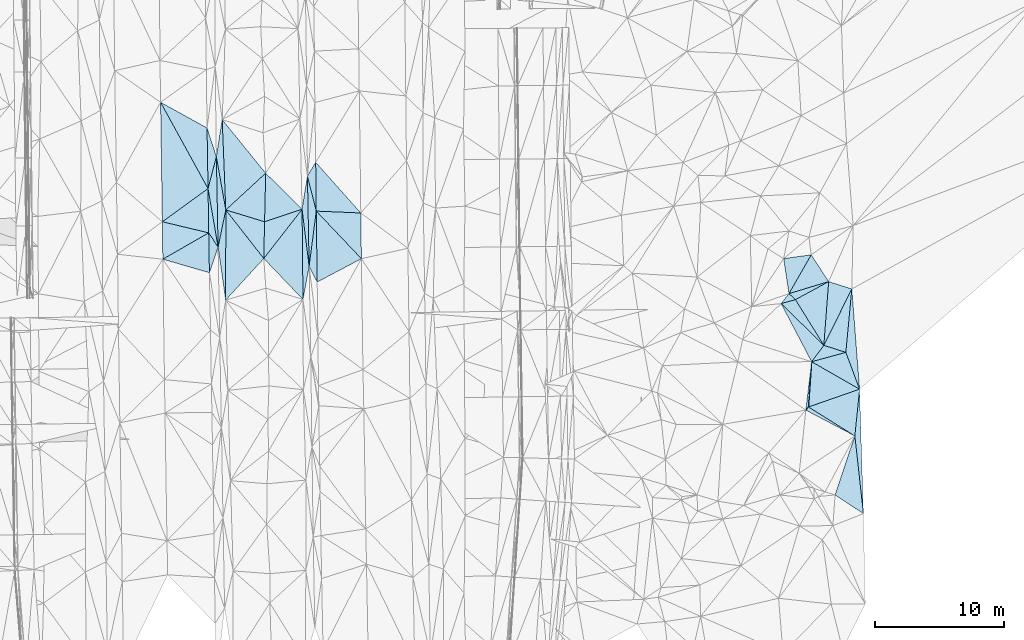
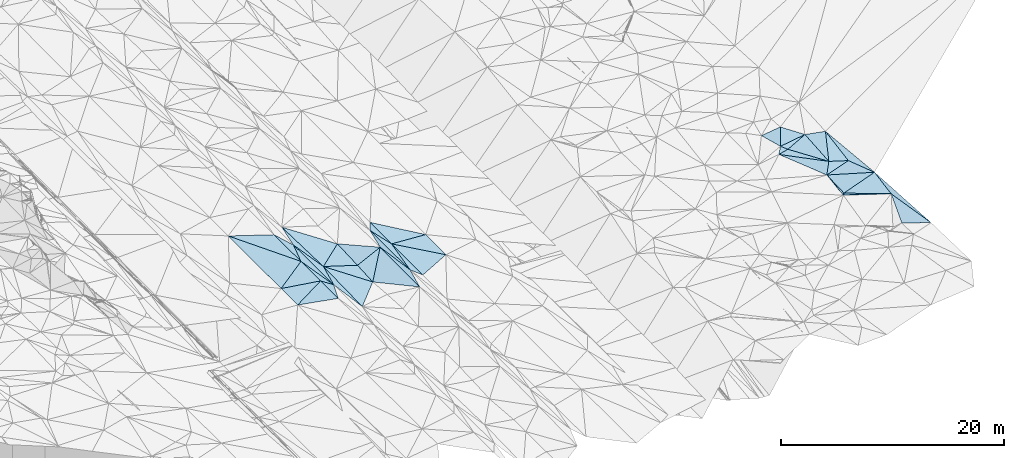
# One storey, part 32 of 275: 45 plates.
"""IFC2X3 building model written with IfcOpenShell, lengths in millimetres."""

from ifc_helpers import new_model, si_unit, frame, origin_with_axes, place, context, subcontext, project, spatial, polyline, outline, extrude, material, type_object, element, save


model = new_model("IFC2X3")

# Units and contexts
model_context = context("Model", 3, precision=1e-05, world=origin_with_axes())
body_context = subcontext(model_context, "Body", "Model", "MODEL_VIEW")
ifc_project = project(units=[si_unit("LENGTHUNIT", "METRE", prefix="MILLI"), si_unit("AREAUNIT", "SQUARE_METRE"), si_unit("VOLUMEUNIT", "CUBIC_METRE"), si_unit("MASSUNIT", "GRAM", prefix="KILO"), si_unit("TIMEUNIT", "SECOND"), si_unit("PLANEANGLEUNIT", "RADIAN"), si_unit("SOLIDANGLEUNIT", "STERADIAN"), si_unit("THERMODYNAMICTEMPERATUREUNIT", "DEGREE_CELSIUS"), si_unit("LUMINOUSINTENSITYUNIT", "LUMEN")], contexts=[model_context])

# Site, building, storey
site_placement = place(None, origin_with_axes())
site = spatial("IfcSite", under=ifc_project, at=site_placement, CompositionType="ELEMENT")
building_placement = place(site_placement, origin_with_axes())
building = spatial("IfcBuilding", under=site, at=building_placement, Name="Undefined", CompositionType="ELEMENT")
storey_placement = place(building_placement, origin_with_axes())
storey = spatial("IfcBuildingStorey", under=building, at=storey_placement, Name="Undefined", CompositionType="ELEMENT", Elevation=0.0)

# Plates
ifc_material = material()
plate_type_1 = type_object("IfcPlateType", PredefinedType="NOTDEFINED")
plate_1_placement = place(storey_placement, frame((-72069.2945186989, 10773.2145581846, 41660.5004244152), z_axis=(-0.0362286607967491, 0.0206914806469052, -0.999129294318565), x_axis=(0.512507171471628, 0.858682571162722, -0.000800731869887081)))
element("IfcPlate", 1, at=plate_1_placement, inside=storey, type_object=plate_type_1, material=ifc_material, Name="00", context=body_context, shape_type="SweptSolid", body=[
    extrude(outline(polyline([(0.0, 0.0), (1248.85791015625, 0.0), (-1978.72314453125, 1979.80322265625), (0.0, 0.0)])), frame((-8.85201319254618e-08, 2.18876761149539e-07, -0.5000001331573), z_axis=(0.0, 0.0, 1.0), x_axis=(1.0, 0.0, 0.0)), (0.0, 0.0, 1.0), 1.0),
])
plate_2_placement = place(storey_placement, frame((-78997.6643263509, 5269.82183594508, 41458.5003683614), z_axis=(-0.0326646940618434, 0.0213431258457143, -0.999238454394636), x_axis=(-0.0191036245456022, 0.999575989404856, 0.021974825016897)))
element("IfcPlate", 2, at=plate_2_placement, inside=storey, type_object=plate_type_1, material=ifc_material, Name="00", context=body_context, shape_type="SweptSolid", body=[
    extrude(outline(polyline([(0.0, 0.0), (7008.01953125, 3.92901711165905e-09), (2868.77783203125, 652.570068359375), (0.0, 0.0)])), frame((-8.85201319254618e-08, 2.18876761149539e-07, -0.5000001331573), z_axis=(0.0, 0.0, 1.0), x_axis=(1.0, 0.0, 0.0)), (0.0, 0.0, 1.0), 1.0),
])
plate_type_2 = type_object("IfcPlateType", PredefinedType="NOTDEFINED")
plate_3_placement = place(storey_placement, frame((-29617.8314992289, -9376.46090840914, 43019.5000497514), z_axis=(0.0117179152314601, 0.00984908836002334, -0.999882836096862), x_axis=(-0.847943675535261, 0.530065356570491, -0.00471602412531869)))
element("IfcPlate", 3, at=plate_3_placement, inside=storey, type_object=plate_type_2, material=ifc_material, Name="00", context=body_context, shape_type="SweptSolid", body=[
    extrude(outline(polyline([(0.0, 0.0), (4240.86083984375, 2.69210431724787e-10), (1613.328125, 3269.20068359375), (0.0, 0.0)])), frame((-8.85201319254618e-08, 2.18876761149539e-07, -0.5000001331573), z_axis=(0.0, 0.0, 1.0), x_axis=(1.0, 0.0, 0.0)), (0.0, 0.0, 1.0), 1.0),
])
plate_type_3 = type_object("IfcPlateType", PredefinedType="NOTDEFINED")
plate_4_placement = place(storey_placement, frame((-29617.8272295952, -9376.45407506971, 43019.50023219), z_axis=(0.0202592197214433, 0.0235158276228421, -0.999518168853119), x_axis=(-0.884878743430388, 0.465769176495077, -0.00697736713630906)))
element("IfcPlate", 4, at=plate_4_placement, inside=storey, type_object=plate_type_3, material=ifc_material, Name="00", context=body_context, shape_type="SweptSolid", body=[
    extrude(outline(polyline([(0.0, 0.0), (4299.6162109375, -1.95723259821534e-09), (4229.19140625, 314.388824462891), (0.0, 0.0)])), frame((-8.85201319254618e-08, 2.18876761149539e-07, -0.5000001331573), z_axis=(0.0, 0.0, 1.0), x_axis=(1.0, 0.0, 0.0)), (0.0, 0.0, 1.0), 1.0),
])
plate_type_4 = type_object("IfcPlateType", PredefinedType="NOTDEFINED")
plate_5_placement = place(storey_placement, frame((-32971.4040485658, -3620.8321723264, 42769.5225685685), z_axis=(-0.0055749306501815, 0.297051615666399, -0.954845148586004), x_axis=(0.579967920625027, 0.778820838591083, 0.238904400173302)))
element("IfcPlate", 5, at=plate_5_placement, inside=storey, type_object=plate_type_4, material=ifc_material, Name="00", context=body_context, shape_type="SweptSolid", body=[
    extrude(outline(polyline([(0.0, 0.0), (1632.4521484375, -1.38970790430903e-09), (2153.63134765625, 1724.0859375), (0.0, 0.0)])), frame((-8.85201319254618e-08, 2.18876761149539e-07, -0.5000001331573), z_axis=(0.0, 0.0, 1.0), x_axis=(1.0, 0.0, 0.0)), (0.0, 0.0, 1.0), 1.0),
])
plate_type_5 = type_object("IfcPlateType", PredefinedType="NOTDEFINED")
plate_6_placement = place(storey_placement, frame((-29856.4552906039, 2020.28152960698, 43049.5025086978), z_axis=(-0.0974667735875479, 0.0233150699635813, -0.994965645416477), x_axis=(-0.0934452463303886, -0.995523518816854, -0.0141742520353913)))
element("IfcPlate", 6, at=plate_6_placement, inside=storey, type_object=plate_type_5, material=ifc_material, Name="00", context=body_context, shape_type="SweptSolid", body=[
    extrude(outline(polyline([(0.0, 0.0), (4938.5322265625, 1.45519152283669e-11), (4551.3525390625, 1759.03149414063), (0.0, 0.0)])), frame((-8.85201319254618e-08, 2.18876761149539e-07, -0.5000001331573), z_axis=(0.0, 0.0, 1.0), x_axis=(1.0, 0.0, 0.0)), (0.0, 0.0, 1.0), 1.0),
])
plate_type_6 = type_object("IfcPlateType", PredefinedType="NOTDEFINED")
plate_7_placement = place(storey_placement, frame((-29253.2685909013, -5749.33980597781, 43059.5020361323), z_axis=(0.0901615201527241, 0.00571671519515485, -0.99591074873762), x_axis=(-0.349456412505503, 0.93658453451358, -0.0262607210252161)))
element("IfcPlate", 7, at=plate_7_placement, inside=storey, type_object=plate_type_6, material=ifc_material, Name="00", context=body_context, shape_type="SweptSolid", body=[
    extrude(outline(polyline([(0.0, 0.0), (3046.375, -1.666194293648e-09), (7487.916015625, 2159.12255859375), (0.0, 0.0)])), frame((-8.85201319254618e-08, 2.18876761149539e-07, -0.5000001331573), z_axis=(0.0, 0.0, 1.0), x_axis=(1.0, 0.0, 0.0)), (0.0, 0.0, 1.0), 1.0),
])
plate_type_7 = type_object("IfcPlateType", PredefinedType="NOTDEFINED")
plate_8_placement = place(storey_placement, frame((-32024.6335716817, -2349.6013640232, 43159.5000668558), z_axis=(-0.00437166216237585, -0.0168261707378649, -0.999848872854412), x_axis=(-0.715073504388953, 0.698995916476401, -0.00863667008854544)))
element("IfcPlate", 8, at=plate_8_placement, inside=storey, type_object=plate_type_7, material=ifc_material, Name="00", context=body_context, shape_type="SweptSolid", body=[
    extrude(outline(polyline([(0.0, 0.0), (4631.41455078125, -5.32418198417872e-09), (4050.29614257813, 995.440307617188), (0.0, 0.0)])), frame((-8.85201319254618e-08, 2.18876761149539e-07, -0.5000001331573), z_axis=(0.0, 0.0, 1.0), x_axis=(1.0, 0.0, 0.0)), (0.0, 0.0, 1.0), 1.0),
])
plate_type_8 = type_object("IfcPlateType", PredefinedType="NOTDEFINED")
plate_9_placement = place(storey_placement, frame((-34225.1346215502, 1193.34036207358, 43109.5247039822), z_axis=(-0.18406286214086, 0.250060162470483, -0.950573920284872), x_axis=(-0.696912779347707, 0.648777578435048, 0.305614514874229)))
element("IfcPlate", 9, at=plate_9_placement, inside=storey, type_object=plate_type_8, material=ifc_material, Name="00", context=body_context, shape_type="SweptSolid", body=[
    extrude(outline(polyline([(0.0, 0.0), (719.861083984375, 9.89530235528946e-10), (-924.900634765625, 2783.06640625), (0.0, 0.0)])), frame((-8.85201319254618e-08, 2.18876761149539e-07, -0.5000001331573), z_axis=(0.0, 0.0, 1.0), x_axis=(1.0, 0.0, 0.0)), (0.0, 0.0, 1.0), 1.0),
])
plate_type_9 = type_object("IfcPlateType", PredefinedType="NOTDEFINED")
plate_10_placement = place(storey_placement, frame((-78408.3111199353, 1156.91155726608, 41343.5004780383), z_axis=(-0.0381194624141933, 0.0224710505639178, -0.999020499525313), x_axis=(-0.141790949562973, 0.989509899082284, 0.0276674220012974)))
element("IfcPlate", 10, at=plate_10_placement, inside=storey, type_object=plate_type_9, material=ifc_material, Name="00", context=body_context, shape_type="SweptSolid", body=[
    extrude(outline(polyline([(0.0, 0.0), (4156.51318359375, 1.86264514923096e-09), (6923.25390625, 1000.43981933594), (0.0, 0.0)])), frame((-8.85201319254618e-08, 2.18876761149539e-07, -0.5000001331573), z_axis=(0.0, 0.0, 1.0), x_axis=(1.0, 0.0, 0.0)), (0.0, 0.0, 1.0), 1.0),
])
plate_type_10 = type_object("IfcPlateType", PredefinedType="NOTDEFINED")
plate_11_placement = place(storey_placement, frame((-71937.6198277511, 3775.88899182083, 41521.5098530379), z_axis=(0.196293473552708, 0.0231633895334249, -0.980271559123254), x_axis=(-0.122711324472165, 0.992441773442597, -0.00112123699516875)))
element("IfcPlate", 11, at=plate_11_placement, inside=storey, type_object=plate_type_10, material=ifc_material, Name="00", context=body_context, shape_type="SweptSolid", body=[
    extrude(outline(polyline([(0.0, 0.0), (4459.36181640625, 3.65980667993426e-09), (6960.42724609375, 742.740234375), (0.0, 0.0)])), frame((-8.85201319254618e-08, 2.18876761149539e-07, -0.5000001331573), z_axis=(0.0, 0.0, 1.0), x_axis=(1.0, 0.0, 0.0)), (0.0, 0.0, 1.0), 1.0),
])
plate_type_11 = type_object("IfcPlateType", PredefinedType="NOTDEFINED")
plate_12_placement = place(storey_placement, frame((-72413.4786573041, 1209.31208122015, 41370.5092665668), z_axis=(0.190423197609623, 0.0224362278492448, -0.981445679338405), x_axis=(-0.0102026085445146, 0.999730040963642, 0.0208746730207218)))
element("IfcPlate", 12, at=plate_12_placement, inside=storey, type_object=plate_type_11, material=ifc_material, Name="00", context=body_context, shape_type="SweptSolid", body=[
    extrude(outline(polyline([(0.0, 0.0), (6994.12158203125, 3.85625753551722e-10), (2564.1806640625, 511.401916503906), (0.0, 0.0)])), frame((-8.85201319254618e-08, 2.18876761149539e-07, -0.5000001331573), z_axis=(0.0, 0.0, 1.0), x_axis=(1.0, 0.0, 0.0)), (0.0, 0.0, 1.0), 1.0),
])
plate_type_12 = type_object("IfcPlateType", PredefinedType="NOTDEFINED")
plate_13_placement = place(storey_placement, frame((-79777.3458007172, 9805.89860804614, 41539.5004275798), z_axis=(0.0347709713656521, 0.0238178317363769, -0.999111450460692), x_axis=(0.169381280690787, -0.985393506083648, -0.0175960199967037)))
element("IfcPlate", 13, at=plate_13_placement, inside=storey, type_object=plate_type_12, material=ifc_material, Name="00", context=body_context, shape_type="SweptSolid", body=[
    extrude(outline(polyline([(0.0, 0.0), (4603.31396484375, -6.34463503956795e-09), (3392.09106445313, 530.393859863281), (0.0, 0.0)])), frame((-8.85201319254618e-08, 2.18876761149539e-07, -0.5000001331573), z_axis=(0.0, 0.0, 1.0), x_axis=(1.0, 0.0, 0.0)), (0.0, 0.0, 1.0), 1.0),
])
plate_type_13 = type_object("IfcPlateType", PredefinedType="NOTDEFINED")
plate_14_placement = place(storey_placement, frame((-71937.7343206055, 3775.88628335474, 41521.5003347778), z_axis=(-0.0326910152039519, 0.0177464525600096, -0.999307941000406), x_axis=(0.127963481471506, 0.991688014118873, 0.0134249790561302)))
element("IfcPlate", 14, at=plate_14_placement, inside=storey, type_object=plate_type_13, material=ifc_material, Name="00", context=body_context, shape_type="SweptSolid", body=[
    extrude(outline(polyline([(0.0, 0.0), (4320.3046875, 1.70257408171892e-09), (-1127.59338378906, 774.342407226563), (0.0, 0.0)])), frame((-8.85201319254618e-08, 2.18876761149539e-07, -0.5000001331573), z_axis=(0.0, 0.0, 1.0), x_axis=(1.0, 0.0, 0.0)), (0.0, 0.0, 1.0), 1.0),
])
plate_type_14 = type_object("IfcPlateType", PredefinedType="NOTDEFINED")
plate_15_placement = place(storey_placement, frame((-71429.2418155258, 11845.5871079936, 41659.5002909619), z_axis=(-0.0280566603072483, 0.0207927409338793, -0.999390056853109), x_axis=(0.664388017727727, -0.74660560180135, -0.034185336895595)))
element("IfcPlate", 15, at=plate_15_placement, inside=storey, type_object=plate_type_14, material=ifc_material, Name="00", context=body_context, shape_type="SweptSolid", body=[
    extrude(outline(polyline([(0.0, 0.0), (5265.41552734375, 8.83301254361868e-09), (2858.3310546875, 2483.31323242188), (0.0, 0.0)])), frame((-8.85201319254618e-08, 2.18876761149539e-07, -0.5000001331573), z_axis=(0.0, 0.0, 1.0), x_axis=(1.0, 0.0, 0.0)), (0.0, 0.0, 1.0), 1.0),
])
plate_type_15 = type_object("IfcPlateType", PredefinedType="NOTDEFINED")
plate_16_placement = place(storey_placement, frame((-28954.337965573, -15402.8511791328, 43279.5158134772), z_axis=(0.249114886189914, -0.014356715638455, -0.968367522273782), x_axis=(-0.109317133517103, 0.993083103218306, -0.0428452380306596)))
element("IfcPlate", 16, at=plate_16_placement, inside=storey, type_object=plate_type_15, material=ifc_material, Name="00", context=body_context, shape_type="SweptSolid", body=[
    extrude(outline(polyline([(0.0, 0.0), (6068.3525390625, 1.04409991763532e-09), (9628.82421875, 783.286315917969), (0.0, 0.0)])), frame((-8.85201319254618e-08, 2.18876761149539e-07, -0.5000001331573), z_axis=(0.0, 0.0, 1.0), x_axis=(1.0, 0.0, 0.0)), (0.0, 0.0, 1.0), 1.0),
])
plate_type_16 = type_object("IfcPlateType", PredefinedType="NOTDEFINED")
plate_17_placement = place(storey_placement, frame((-78400.3644919204, 8150.30887487595, 41500.500335842), z_axis=(-0.0302412042234595, 0.0217745656507073, -0.999305427713589), x_axis=(-0.17449004646911, 0.984296113519671, 0.0267279739838045)))
element("IfcPlate", 17, at=plate_17_placement, inside=storey, type_object=plate_type_16, material=ifc_material, Name="00", context=body_context, shape_type="SweptSolid", body=[
    extrude(outline(polyline([(0.0, 0.0), (4190.3662109375, -1.32422428578138e-09), (6945.3623046875, 948.727172851563), (0.0, 0.0)])), frame((-8.85201319254618e-08, 2.18876761149539e-07, -0.5000001331573), z_axis=(0.0, 0.0, 1.0), x_axis=(1.0, 0.0, 0.0)), (0.0, 0.0, 1.0), 1.0),
])
plate_type_17 = type_object("IfcPlateType", PredefinedType="NOTDEFINED")
plate_18_placement = place(storey_placement, frame((-79131.5130728407, 12274.8704145974, 41612.5002920806), z_axis=(0.0269979350420623, 0.0224865494646011, -0.999382542671544), x_axis=(0.0191036246765628, -0.99957598940211, -0.0219748250279874)))
element("IfcPlate", 18, at=plate_18_placement, inside=storey, type_object=plate_type_17, material=ifc_material, Name="00", context=body_context, shape_type="SweptSolid", body=[
    extrude(outline(polyline([(0.0, 0.0), (7008.01953125, 3.92901711165905e-09), (2457.19189453125, 693.157104492188), (0.0, 0.0)])), frame((-8.85201319254618e-08, 2.18876761149539e-07, -0.5000001331573), z_axis=(0.0, 0.0, 1.0), x_axis=(1.0, 0.0, 0.0)), (0.0, 0.0, 1.0), 1.0),
])
plate_type_18 = type_object("IfcPlateType", PredefinedType="NOTDEFINED")
plate_19_placement = place(storey_placement, frame((-32971.3340226437, -3621.01774324677, 42769.5059195711), z_axis=(0.134479675008049, -0.0740907131661643, -0.988142592560537), x_axis=(-0.0688098693906279, -0.99549188341705, 0.0652771929943377)))
element("IfcPlate", 19, at=plate_19_placement, inside=storey, type_object=plate_type_18, material=ifc_material, Name="00", context=body_context, shape_type="SweptSolid", body=[
    extrude(outline(polyline([(0.0, 0.0), (3523.43579101563, -7.27595761418343e-12), (3781.33740234375, 193.097717285156), (0.0, 0.0)])), frame((-8.85201319254618e-08, 2.18876761149539e-07, -0.5000001331573), z_axis=(0.0, 0.0, 1.0), x_axis=(1.0, 0.0, 0.0)), (0.0, 0.0, 1.0), 1.0),
])
plate_type_19 = type_object("IfcPlateType", PredefinedType="NOTDEFINED")
plate_20_placement = place(storey_placement, frame((-71937.7393478444, 3775.88693046452, 41521.5005375051), z_axis=(-0.0427516943767761, 0.0190391785103247, -0.998904300876499), x_axis=(-0.018794212532507, 0.999626162668964, 0.0198573030143951)))
element("IfcPlate", 20, at=plate_20_placement, inside=storey, type_object=plate_type_19, material=ifc_material, Name="00", context=body_context, shape_type="SweptSolid", body=[
    extrude(outline(polyline([(0.0, 0.0), (6999.94384765625, 1.45519152283669e-11), (4273.55419921875, 633.850891113281), (0.0, 0.0)])), frame((-8.85201319254618e-08, 2.18876761149539e-07, -0.5000001331573), z_axis=(0.0, 0.0, 1.0), x_axis=(1.0, 0.0, 0.0)), (0.0, 0.0, 1.0), 1.0),
])
plate_type_20 = type_object("IfcPlateType", PredefinedType="NOTDEFINED")
plate_21_placement = place(storey_placement, frame((-79854.4249594771, 14506.0953585428, 41639.500327787), z_axis=(0.0298065228343066, 0.0217499975631259, -0.999319022536113), x_axis=(0.308203660615518, -0.951250755090081, -0.0115110609304567)))
element("IfcPlate", 21, at=plate_21_placement, inside=storey, type_object=plate_type_20, material=ifc_material, Name="00", context=body_context, shape_type="SweptSolid", body=[
    extrude(outline(polyline([(0.0, 0.0), (2345.57006835938, 2.57568899542093e-09), (4495.97314453125, 1376.23608398438), (0.0, 0.0)])), frame((-8.85201319254618e-08, 2.18876761149539e-07, -0.5000001331573), z_axis=(0.0, 0.0, 1.0), x_axis=(1.0, 0.0, 0.0)), (0.0, 0.0, 1.0), 1.0),
])
plate_type_21 = type_object("IfcPlateType", PredefinedType="NOTDEFINED")
plate_22_placement = place(storey_placement, frame((-83458.0415543271, 16499.191319917, 41559.5003950391), z_axis=(0.0342497263328102, 0.021819797395307, -0.999175086102408), x_axis=(0.87490962547946, -0.483896577509655, 0.0194229121872648)))
element("IfcPlate", 22, at=plate_22_placement, inside=storey, type_object=plate_type_21, material=ifc_material, Name="00", context=body_context, shape_type="SweptSolid", body=[
    extrude(outline(polyline([(0.0, 0.0), (4118.84716796875, 5.35874278284609e-09), (6458.74951171875, 4078.3154296875), (0.0, 0.0)])), frame((-8.85201319254618e-08, 2.18876761149539e-07, -0.5000001331573), z_axis=(0.0, 0.0, 1.0), x_axis=(1.0, 0.0, 0.0)), (0.0, 0.0, 1.0), 1.0),
])
plate_type_22 = type_object("IfcPlateType", PredefinedType="NOTDEFINED")
plate_23_placement = place(storey_placement, frame((-35336.3455875958, 887.830445882165, 43119.5148699332), z_axis=(0.175151574108623, 0.167192097533723, -0.970241582601749), x_axis=(0.715073504389042, -0.698995916476325, 0.00863667008731589)))
element("IfcPlate", 23, at=plate_23_placement, inside=storey, type_object=plate_type_22, material=ifc_material, Name="00", context=body_context, shape_type="SweptSolid", body=[
    extrude(outline(polyline([(0.0, 0.0), (4631.41455078125, -5.32418198417872e-09), (4839.73095703125, 1619.10595703125), (0.0, 0.0)])), frame((-8.85201319254618e-08, 2.18876761149539e-07, -0.5000001331573), z_axis=(0.0, 0.0, 1.0), x_axis=(1.0, 0.0, 0.0)), (0.0, 0.0, 1.0), 1.0),
])
plate_type_23 = type_object("IfcPlateType", PredefinedType="NOTDEFINED")
plate_24_placement = place(storey_placement, frame((-75456.0650958946, 4384.18785175041, 41056.5039110342), z_axis=(0.122664062618758, 0.0240828849431344, -0.992156007084913), x_axis=(0.0222641544438705, 0.999387168547204, 0.0270110120155027)))
element("IfcPlate", 24, at=plate_24_placement, inside=storey, type_object=plate_type_23, material=ifc_material, Name="00", context=body_context, shape_type="SweptSolid", body=[
    extrude(outline(polyline([(0.0, 0.0), (2850.68920898438, 5.82076609134674e-10), (3893.59521484375, 2907.18701171875), (0.0, 0.0)])), frame((-8.85201319254618e-08, 2.18876761149539e-07, -0.5000001331573), z_axis=(0.0, 0.0, 1.0), x_axis=(1.0, 0.0, 0.0)), (0.0, 0.0, 1.0), 1.0),
])
plate_type_24 = type_object("IfcPlateType", PredefinedType="NOTDEFINED")
plate_25_placement = place(storey_placement, frame((-79725.196599748, 6373.91760922363, 41459.5002900651), z_axis=(0.0288335370086573, 0.0199055082190157, -0.999386010451474), x_axis=(0.550241001644791, -0.835005549771769, -0.0007562798972526)))
element("IfcPlate", 25, at=plate_25_placement, inside=storey, type_object=plate_type_24, material=ifc_material, Name="00", context=body_context, shape_type="SweptSolid", body=[
    extrude(outline(polyline([(0.0, 0.0), (1322.26245117188, 2.3719621822238e-09), (2611.93237304688, 1656.47509765625), (0.0, 0.0)])), frame((-8.85201319254618e-08, 2.18876761149539e-07, -0.5000001331573), z_axis=(0.0, 0.0, 1.0), x_axis=(1.0, 0.0, 0.0)), (0.0, 0.0, 1.0), 1.0),
])
plate_type_25 = type_object("IfcPlateType", PredefinedType="NOTDEFINED")
plate_26_placement = place(storey_placement, frame((-34726.7730892664, 1660.4120113785, 43329.531353421), z_axis=(-0.100200954031058, 0.33387944277826, -0.937274925782902), x_axis=(0.696912779349073, -0.64877757843585, -0.30561451486941)))
element("IfcPlate", 26, at=plate_26_placement, inside=storey, type_object=plate_type_25, material=ifc_material, Name="00", context=body_context, shape_type="SweptSolid", body=[
    extrude(outline(polyline([(0.0, 0.0), (719.861083984375, 9.89530235528946e-10), (140.443756103516, 996.431396484375), (0.0, 0.0)])), frame((-8.85201319254618e-08, 2.18876761149539e-07, -0.5000001331573), z_axis=(0.0, 0.0, 1.0), x_axis=(1.0, 0.0, 0.0)), (0.0, 0.0, 1.0), 1.0),
])
plate_type_26 = type_object("IfcPlateType", PredefinedType="NOTDEFINED")
plate_27_placement = place(storey_placement, frame((-28954.4436001207, -15402.8634578152, 43279.5007344527), z_axis=(0.0378461355791359, -0.0389140003360954, -0.9985255983697), x_axis=(-0.832274533119522, 0.551819525489065, -0.0530500971696034)))
element("IfcPlate", 27, at=plate_27_placement, inside=storey, type_object=plate_type_26, material=ifc_material, Name="00", context=body_context, shape_type="SweptSolid", body=[
    extrude(outline(polyline([(0.0, 0.0), (2639.01489257813, 7.53061613067985e-10), (3891.37622070313, 4656.4033203125), (0.0, 0.0)])), frame((-8.85201319254618e-08, 2.18876761149539e-07, -0.5000001331573), z_axis=(0.0, 0.0, 1.0), x_axis=(1.0, 0.0, 0.0)), (0.0, 0.0, 1.0), 1.0),
])
plate_type_27 = type_object("IfcPlateType", PredefinedType="NOTDEFINED")
plate_28_placement = place(storey_placement, frame((-75456.1869262243, 4384.1870275886, 41056.5037866032), z_axis=(-0.120983597578037, 0.022416564138349, -0.99240136374821), x_axis=(-0.673509309934628, -0.736273081642007, 0.0654763978908748)))
element("IfcPlate", 28, at=plate_28_placement, inside=storey, type_object=plate_type_27, material=ifc_material, Name="00", context=body_context, shape_type="SweptSolid", body=[
    extrude(outline(polyline([(0.0, 0.0), (4383.2587890625, -1.46101228892803e-08), (-760.861267089844, 4740.2900390625), (0.0, 0.0)])), frame((-8.85201319254618e-08, 2.18876761149539e-07, -0.5000001331573), z_axis=(0.0, 0.0, 1.0), x_axis=(1.0, 0.0, 0.0)), (0.0, 0.0, 1.0), 1.0),
])
plate_type_28 = type_object("IfcPlateType", PredefinedType="NOTDEFINED")
plate_29_placement = place(storey_placement, frame((-34726.7101864405, 1660.18667761489, 43329.5035773239), z_axis=(0.0256055393781179, -0.11678712593334, -0.992826834634009), x_axis=(-0.149320021666795, 0.981563989224028, -0.119313311026224)))
element("IfcPlate", 29, at=plate_29_placement, inside=storey, type_object=plate_type_28, material=ifc_material, Name="00", context=body_context, shape_type="SweptSolid", body=[
    extrude(outline(polyline([(0.0, 0.0), (2765.8271484375, -3.20142135024071e-10), (2737.01123046875, 2152.34057617188), (0.0, 0.0)])), frame((-8.85201319254618e-08, 2.18876761149539e-07, -0.5000001331573), z_axis=(0.0, 0.0, 1.0), x_axis=(1.0, 0.0, 0.0)), (0.0, 0.0, 1.0), 1.0),
])
plate_type_29 = type_object("IfcPlateType", PredefinedType="NOTDEFINED")
plate_30_placement = place(storey_placement, frame((-75392.7143634064, 7233.13270846437, 41133.503364712), z_axis=(-0.112247667849426, 0.0293456857792431, -0.993246843331763), x_axis=(-0.0222641544516399, -0.999387168547397, -0.0270110120019804)))
element("IfcPlate", 30, at=plate_30_placement, inside=storey, type_object=plate_type_29, material=ifc_material, Name="00", context=body_context, shape_type="SweptSolid", body=[
    extrude(outline(polyline([(0.0, 0.0), (2850.68920898438, 5.82076609134674e-10), (-859.567199707031, 3046.84399414063), (0.0, 0.0)])), frame((-8.85201319254618e-08, 2.18876761149539e-07, -0.5000001331573), z_axis=(0.0, 0.0, 1.0), x_axis=(1.0, 0.0, 0.0)), (0.0, 0.0, 1.0), 1.0),
])
plate_type_30 = type_object("IfcPlateType", PredefinedType="NOTDEFINED")
plate_31_placement = place(storey_placement, frame((-33007.9664597308, 4672.43162831301, 43019.5029852294), z_axis=(-0.0992771397524703, -0.0456494198252427, -0.994012162899523), x_axis=(0.54636145576523, -0.837394525981878, -0.0161110989595404)))
element("IfcPlate", 31, at=plate_31_placement, inside=storey, type_object=plate_type_30, material=ifc_material, Name="00", context=body_context, shape_type="SweptSolid", body=[
    extrude(outline(polyline([(0.0, 0.0), (2482.76049804688, 1.46246748045087e-09), (1578.32373046875, 3103.658203125), (0.0, 0.0)])), frame((-8.85201319254618e-08, 2.18876761149539e-07, -0.5000001331573), z_axis=(0.0, 0.0, 1.0), x_axis=(1.0, 0.0, 0.0)), (0.0, 0.0, 1.0), 1.0),
])
plate_type_31 = type_object("IfcPlateType", PredefinedType="NOTDEFINED")
plate_32_placement = place(storey_placement, frame((-32024.6473760586, -2349.60993134453, 43159.5005355881), z_axis=(-0.0319810513476786, -0.0339609201404722, -0.998911341540334), x_axis=(-0.527571886775126, 0.849425801023097, -0.0119880290625087)))
element("IfcPlate", 32, at=plate_32_placement, inside=storey, type_object=plate_type_31, material=ifc_material, Name="00", context=body_context, shape_type="SweptSolid", body=[
    extrude(outline(polyline([(0.0, 0.0), (4170.8271484375, 1.37733877636492e-08), (4003.97778320313, 2927.97900390625), (0.0, 0.0)])), frame((-8.85201319254618e-08, 2.18876761149539e-07, -0.5000001331573), z_axis=(0.0, 0.0, 1.0), x_axis=(1.0, 0.0, 0.0)), (0.0, 0.0, 1.0), 1.0),
])
plate_type_32 = type_object("IfcPlateType", PredefinedType="NOTDEFINED")
plate_33_placement = place(storey_placement, frame((-31651.4187994133, 2593.38515565012, 42979.5005384797), z_axis=(0.0266961562383421, -0.0383908949760449, -0.998906128935565), x_axis=(0.951963512477663, -0.303952832476015, 0.0371233961404143)))
element("IfcPlate", 33, at=plate_33_placement, inside=storey, type_object=plate_type_32, material=ifc_material, Name="00", context=body_context, shape_type="SweptSolid", body=[
    extrude(outline(polyline([(0.0, 0.0), (1885.60339355469, 2.24281393457204e-09), (1153.84814453125, 4824.26513671875), (0.0, 0.0)])), frame((-8.85201319254618e-08, 2.18876761149539e-07, -0.5000001331573), z_axis=(0.0, 0.0, 1.0), x_axis=(1.0, 0.0, 0.0)), (0.0, 0.0, 1.0), 1.0),
])
plate_type_33 = type_object("IfcPlateType", PredefinedType="NOTDEFINED")
plate_34_placement = place(storey_placement, frame((-30317.8496487846, -2896.15437793606, 42979.5015359777), z_axis=(0.0785277388952072, 0.00134789732725359, -0.996911017792863), x_axis=(0.349456412505179, -0.936584534513689, 0.0262607210256392)))
element("IfcPlate", 34, at=plate_34_placement, inside=storey, type_object=plate_type_33, material=ifc_material, Name="00", context=body_context, shape_type="SweptSolid", body=[
    extrude(outline(polyline([(0.0, 0.0), (3046.375, -1.666194293648e-09), (-253.941162109375, 2747.01904296875), (0.0, 0.0)])), frame((-8.85201319254618e-08, 2.18876761149539e-07, -0.5000001331573), z_axis=(0.0, 0.0, 1.0), x_axis=(1.0, 0.0, 0.0)), (0.0, 0.0, 1.0), 1.0),
])
plate_type_34 = type_object("IfcPlateType", PredefinedType="NOTDEFINED")
plate_35_placement = place(storey_placement, frame((-32971.3818612546, -3621.01472449213, 42769.501527553), z_axis=(0.0388013318607117, -0.0680532951251745, -0.996926880803422), x_axis=(0.865885278455705, -0.495662689523304, 0.0675365291395005)))
element("IfcPlate", 35, at=plate_35_placement, inside=storey, type_object=plate_type_34, material=ifc_material, Name="00", context=body_context, shape_type="SweptSolid", body=[
    extrude(outline(polyline([(0.0, 0.0), (4293.97265625, 6.98491930961609e-09), (1544.16455078125, 3167.04223632813), (0.0, 0.0)])), frame((-8.85201319254618e-08, 2.18876761149539e-07, -0.5000001331573), z_axis=(0.0, 0.0, 1.0), x_axis=(1.0, 0.0, 0.0)), (0.0, 0.0, 1.0), 1.0),
])
plate_type_35 = type_object("IfcPlateType", PredefinedType="NOTDEFINED")
plate_36_placement = place(storey_placement, frame((-72484.8695062982, 8201.54527515403, 41516.5040516883), z_axis=(0.12530998783406, 0.021989468689485, -0.991873918507681), x_axis=(0.010202608511522, -0.999730040964849, -0.0208746729790327)))
element("IfcPlate", 36, at=plate_36_placement, inside=storey, type_object=plate_type_35, material=ifc_material, Name="00", context=body_context, shape_type="SweptSolid", body=[
    extrude(outline(polyline([(0.0, 0.0), (6994.12158203125, 3.85625753551722e-10), (3795.61645507813, 3033.99365234375), (0.0, 0.0)])), frame((-8.85201319254618e-08, 2.18876761149539e-07, -0.5000001331573), z_axis=(0.0, 0.0, 1.0), x_axis=(1.0, 0.0, 0.0)), (0.0, 0.0, 1.0), 1.0),
])
plate_type_36 = type_object("IfcPlateType", PredefinedType="NOTDEFINED")
plate_37_placement = place(storey_placement, frame((-79777.3464419225, 9805.89859898504, 41539.5004053524), z_axis=(0.0334889394242934, 0.0237993810719909, -0.999155683763459), x_axis=(0.0151900666738862, -0.999613084358831, -0.0233011470332815)))
element("IfcPlate", 37, at=plate_37_placement, inside=storey, type_object=plate_type_36, material=ifc_material, Name="00", context=body_context, shape_type="SweptSolid", body=[
    extrude(outline(polyline([(0.0, 0.0), (3433.30737304688, 3.34694050252438e-09), (2521.4169921875, 3583.24658203125), (0.0, 0.0)])), frame((-8.85201319254618e-08, 2.18876761149539e-07, -0.5000001331573), z_axis=(0.0, 0.0, 1.0), x_axis=(1.0, 0.0, 0.0)), (0.0, 0.0, 1.0), 1.0),
])
plate_type_37 = type_object("IfcPlateType", PredefinedType="NOTDEFINED")
plate_38_placement = place(storey_placement, frame((-83282.9240595545, 4330.91524064612, 41299.5003623984), z_axis=(0.0328384890859798, 0.0210707997519173, -0.999238537603692), x_axis=(-0.0127230316617355, 0.999705548932283, 0.0206625240311307)))
element("IfcPlate", 38, at=plate_38_placement, inside=storey, type_object=plate_type_37, material=ifc_material, Name="00", context=body_context, shape_type="SweptSolid", body=[
    extrude(outline(polyline([(0.0, 0.0), (2903.80786132813, 6.11180439591408e-10), (2000.44226074219, 3585.4052734375), (0.0, 0.0)])), frame((-8.85201319254618e-08, 2.18876761149539e-07, -0.5000001331573), z_axis=(0.0, 0.0, 1.0), x_axis=(1.0, 0.0, 0.0)), (0.0, 0.0, 1.0), 1.0),
])
plate_type_38 = type_object("IfcPlateType", PredefinedType="NOTDEFINED")
plate_39_placement = place(storey_placement, frame((-79725.1942839671, 6373.91764829544, 41459.5003624177), z_axis=(0.0334621950587156, 0.0199847920217257, -0.999240156113484), x_axis=(0.0177343136613877, -0.999654522920694, -0.019399199033967)))
element("IfcPlate", 39, at=plate_39_placement, inside=storey, type_object=plate_type_38, material=ifc_material, Name="00", context=body_context, shape_type="SweptSolid", body=[
    extrude(outline(polyline([(0.0, 0.0), (3092.9111328125, 1.32422428578138e-09), (1982.30712890625, 3595.46362304688), (0.0, 0.0)])), frame((-8.85201319254618e-08, 2.18876761149539e-07, -0.5000001331573), z_axis=(0.0, 0.0, 1.0), x_axis=(1.0, 0.0, 0.0)), (0.0, 0.0, 1.0), 1.0),
])
plate_type_39 = type_object("IfcPlateType", PredefinedType="NOTDEFINED")
plate_40_placement = place(storey_placement, frame((-71384.8930788326, 8060.28071156602, 41579.500331651), z_axis=(-0.0326779939931858, 0.017746626573826, -0.999308363796596), x_axis=(0.68787640285371, -0.724965597918647, -0.0353685768938832)))
element("IfcPlate", 40, at=plate_40_placement, inside=storey, type_object=plate_type_39, material=ifc_material, Name="00", context=body_context, shape_type="SweptSolid", body=[
    extrude(outline(polyline([(0.0, 0.0), (5089.26318359375, -7.15954229235649e-09), (4040.23120117188, 3735.73706054688), (0.0, 0.0)])), frame((-8.85201319254618e-08, 2.18876761149539e-07, -0.5000001331573), z_axis=(0.0, 0.0, 1.0), x_axis=(1.0, 0.0, 0.0)), (0.0, 0.0, 1.0), 1.0),
])
plate_type_40 = type_object("IfcPlateType", PredefinedType="NOTDEFINED")
plate_41_placement = place(storey_placement, frame((-71384.8907383209, 8060.28293374105, 41579.5003049599), z_axis=(-0.0279967821431628, 0.0221909495176321, -0.999361667240211), x_axis=(0.998691462811239, -0.0421818043209652, -0.0289146587767473)))
element("IfcPlate", 41, at=plate_41_placement, inside=storey, type_object=plate_type_40, material=ifc_material, Name="00", context=body_context, shape_type="SweptSolid", body=[
    extrude(outline(polyline([(0.0, 0.0), (3458.45336914063, 9.84709913609549e-09), (3657.03930664063, 3539.302734375), (0.0, 0.0)])), frame((-8.85201319254618e-08, 2.18876761149539e-07, -0.5000001331573), z_axis=(0.0, 0.0, 1.0), x_axis=(1.0, 0.0, 0.0)), (0.0, 0.0, 1.0), 1.0),
])
plate_type_41 = type_object("IfcPlateType", PredefinedType="NOTDEFINED")
plate_42_placement = place(storey_placement, frame((-83458.0413183233, 16499.1914558909, 41559.5004101518), z_axis=(0.0347331032477596, 0.0220855427624614, -0.999152561093484), x_axis=(0.48185517744757, -0.876246958660469, -0.00261828288200102)))
element("IfcPlate", 42, at=plate_42_placement, inside=storey, type_object=plate_type_41, material=ifc_material, Name="00", context=body_context, shape_type="SweptSolid", body=[
    extrude(outline(polyline([(0.0, 0.0), (7638.5927734375, 1.04482751339674e-08), (8185.81396484375, 4347.154296875), (0.0, 0.0)])), frame((-8.85201319254618e-08, 2.18876761149539e-07, -0.5000001331573), z_axis=(0.0, 0.0, 1.0), x_axis=(1.0, 0.0, 0.0)), (0.0, 0.0, 1.0), 1.0),
])
plate_type_42 = type_object("IfcPlateType", PredefinedType="NOTDEFINED")
plate_43_placement = place(storey_placement, frame((-75308.1595209992, 10998.887192163, 41171.5038114083), z_axis=(-0.122130130809752, 0.0179645162550421, -0.992351503905806), x_axis=(-0.733249661327276, -0.675469271033725, 0.0780140888083828)))
element("IfcPlate", 43, at=plate_43_placement, inside=storey, type_object=plate_type_42, material=ifc_material, Name="00", context=body_context, shape_type="SweptSolid", body=[
    extrude(outline(polyline([(0.0, 0.0), (4217.18701171875, -1.30530679598451e-08), (-296.254364013672, 5363.486328125), (0.0, 0.0)])), frame((-8.85201319254618e-08, 2.18876761149539e-07, -0.5000001331573), z_axis=(0.0, 0.0, 1.0), x_axis=(1.0, 0.0, 0.0)), (0.0, 0.0, 1.0), 1.0),
])
plate_type_43 = type_object("IfcPlateType", PredefinedType="NOTDEFINED")
plate_44_placement = place(storey_placement, frame((-75392.5941161708, 7233.12159710586, 41133.5041311135), z_axis=(0.128253093428971, 0.0071274185326457, -0.991715858464994), x_axis=(0.0224481054540133, 0.999697112869843, 0.0100878680218776)))
element("IfcPlate", 44, at=plate_44_placement, inside=storey, type_object=plate_type_43, material=ifc_material, Name="00", context=body_context, shape_type="SweptSolid", body=[
    extrude(outline(polyline([(0.0, 0.0), (3766.90112304688, -1.68802216649055e-09), (1037.25952148438, 2909.20654296875), (0.0, 0.0)])), frame((-8.85201319254618e-08, 2.18876761149539e-07, -0.5000001331573), z_axis=(0.0, 0.0, 1.0), x_axis=(1.0, 0.0, 0.0)), (0.0, 0.0, 1.0), 1.0),
])
plate_type_44 = type_object("IfcPlateType", PredefinedType="NOTDEFINED")
plate_45_placement = place(storey_placement, frame((-75308.1571039697, 10998.8845285056, 41171.5034816539), z_axis=(-0.117309214329262, 0.0126546048596782, -0.993014808152072), x_axis=(-0.0224481054544382, -0.99969711286983, -0.0100878680221596)))
element("IfcPlate", 45, at=plate_45_placement, inside=storey, type_object=plate_type_44, material=ifc_material, Name="00", context=body_context, shape_type="SweptSolid", body=[
    extrude(outline(polyline([(0.0, 0.0), (3766.90112304688, -1.68802216649055e-09), (2913.81372070313, 3048.66455078125), (0.0, 0.0)])), frame((-8.85201319254618e-08, 2.18876761149539e-07, -0.5000001331573), z_axis=(0.0, 0.0, 1.0), x_axis=(1.0, 0.0, 0.0)), (0.0, 0.0, 1.0), 1.0),
])

save(model, "model.ifc")
